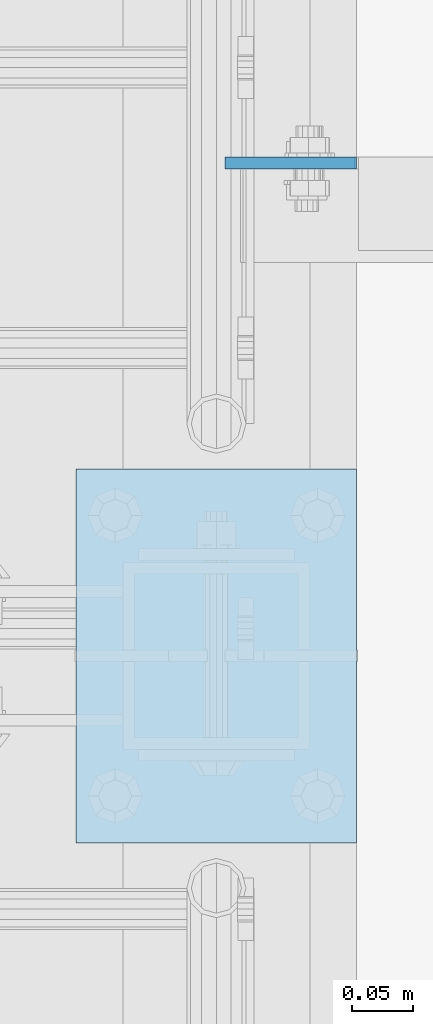
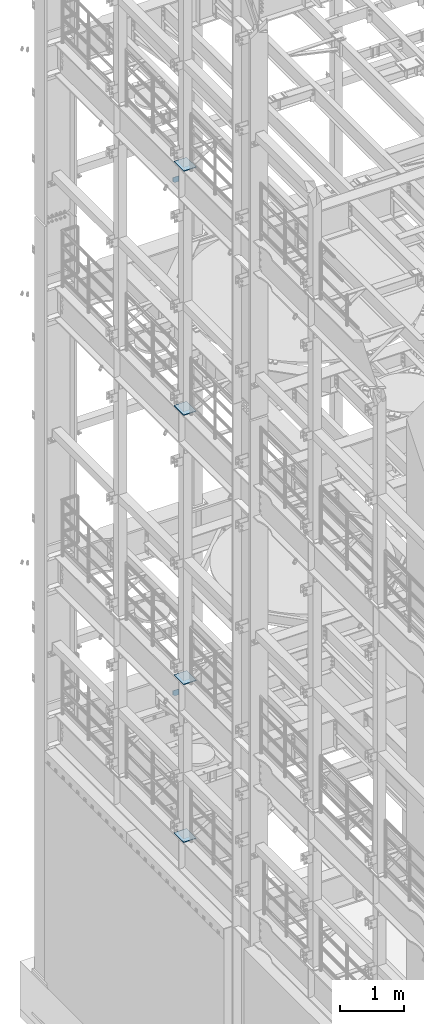
# One storey, part 1708 of 1876: 6 plates, 6 elements without a shape of their own.
"""IFC2X3 building model written with IfcOpenShell, lengths in millimetres."""

from ifc_helpers import new_model, si_unit, frame, origin_with_axes, place, context, subcontext, project, spatial, faceted_brep, material, type_object, element, aggregate, save


model = new_model("IFC2X3")

# Units and contexts
model_context = context("Model", 3, precision=1e-05, world=origin_with_axes())
body_context = subcontext(model_context, "Body", "Model", "MODEL_VIEW")
ifc_project = project(units=[si_unit("LENGTHUNIT", "METRE", prefix="MILLI"), si_unit("AREAUNIT", "SQUARE_METRE"), si_unit("VOLUMEUNIT", "CUBIC_METRE"), si_unit("MASSUNIT", "GRAM", prefix="KILO"), si_unit("TIMEUNIT", "SECOND"), si_unit("PLANEANGLEUNIT", "RADIAN"), si_unit("SOLIDANGLEUNIT", "STERADIAN"), si_unit("THERMODYNAMICTEMPERATUREUNIT", "DEGREE_CELSIUS"), si_unit("LUMINOUSINTENSITYUNIT", "LUMEN")], contexts=[model_context])

# Site, building, storey
site_placement = place(None, origin_with_axes())
site = spatial("IfcSite", under=ifc_project, at=site_placement, CompositionType="ELEMENT")
building_placement = place(site_placement, origin_with_axes())
building = spatial("IfcBuilding", under=site, at=building_placement, Name="Undefined", CompositionType="ELEMENT")
storey_placement = place(building_placement, origin_with_axes())
storey = spatial("IfcBuildingStorey", under=building, at=storey_placement, Name="Undefined", CompositionType="ELEMENT", Elevation=0.0)

# Assembly, plate
assembly_1_placement = place(storey_placement, origin_with_axes())
assembly_1 = element("IfcElementAssembly", 1, at=assembly_1_placement, inside=storey, Name="BEAM", AssemblyPlace="NOTDEFINED", PredefinedType="RIGID_FRAME")
ifc_material = material(Name="STEEL/A36")
plate_type_1 = type_object("IfcPlateType", PredefinedType="NOTDEFINED")
plate_1_placement = place(assembly_1_placement, frame((114.355426115311, 10053.6375, 17386.3), z_axis=(-1.0, 0.0, 0.0), x_axis=(0.0, 0.0, 1.0)))
plate_1 = element("IfcPlate", 2, at=plate_1_placement, type_object=plate_type_1, material=ifc_material, Name="PLATE", context=body_context, shape_type="Brep", body=[
    faceted_brep([(0.0, -4.76249999999982, 0.0), (0.0, -4.76250000000073, 75.4616775512695), (0.0, 4.76250000000073, 75.4616775512695), (0.0, 4.76249999999982, 0.0), (31.75, -4.76250000000073, 107.21167755127), (31.75, 4.76250000000073, 107.21167755127), (102.393173217773, -4.76250000000073, 107.21167755127), (102.393173217773, 4.76250000000073, 107.21167755127), (102.393173217773, -4.76250000000073, 0.0), (102.393173217773, 4.76250000000073, 0.0)], [[[0, 1, 2, 3]], [[1, 4, 5, 2]], [[4, 6, 7, 5]], [[6, 8, 9, 7]], [[8, 0, 3, 9]], [[5, 7, 9, 3, 2]], [[8, 6, 4, 1, 0]]]),
])
aggregate(assembly_1, [plate_1])

assembly_2_placement = place(storey_placement, origin_with_axes())
assembly_2 = element("IfcElementAssembly", 3, at=assembly_2_placement, inside=storey, Name="BEAM", AssemblyPlace="NOTDEFINED", PredefinedType="RIGID_FRAME")
plate_type_2 = type_object("IfcPlateType", PredefinedType="NOTDEFINED")
plate_2_placement = place(assembly_2_placement, frame((7.14374999999999, 10053.6375, 7556.5), z_axis=(0.0, 0.0, 1.0), x_axis=(1.0, 0.0, 0.0)))
plate_2 = element("IfcPlate", 4, at=plate_2_placement, type_object=plate_type_2, material=ifc_material, Name="PLATE", context=body_context, shape_type="Brep", body=[
    faceted_brep([(-9.76996261670138e-14, -4.76250000000073, 31.75), (-1.00364161426114e-13, -4.76250000000073, 106.301628112793), (-1.00364161426114e-13, 4.76250000000073, 106.301628112793), (-9.76996261670138e-14, 4.76250000000073, 31.75), (106.018096923828, -4.76250000000073, 106.301628112793), (106.018096923828, 4.76250000000073, 106.301628112793), (106.018096923828, -4.76250000000073, 0.0), (106.018096923828, 4.76250000000073, 0.0), (31.75, -4.76250000000073, 0.0), (31.75, 4.76250000000073, 0.0)], [[[0, 1, 2, 3]], [[1, 4, 5, 2]], [[4, 6, 7, 5]], [[6, 8, 9, 7]], [[8, 0, 3, 9]], [[5, 7, 9, 3, 2]], [[8, 6, 4, 1, 0]]]),
])
aggregate(assembly_2, [plate_2])

assembly_3_placement = place(storey_placement, origin_with_axes())
assembly_3 = element("IfcElementAssembly", 5, at=assembly_3_placement, inside=storey, Name="BEAM", AssemblyPlace="NOTDEFINED", PredefinedType="RIGID_FRAME")
plate_type_3 = type_object("IfcPlateType", PredefinedType="NOTDEFINED")
plate_3_placement = place(assembly_3_placement, frame((-114.3, 9499.6, 17989.55), z_axis=(0.0, 1.0, 0.0), x_axis=(1.0, 0.0, 0.0)))
plate_3 = element("IfcPlate", 6, at=plate_3_placement, type_object=plate_type_3, material=ifc_material, Name="PLATE", context=body_context, shape_type="Brep", body=[
    faceted_brep([(0.0, -6.35000000000036, 0.0), (0.0, -6.35000000000036, 304.799987792969), (0.0, 6.35000000000036, 304.799987792969), (0.0, 6.35000000000036, 0.0), (228.600006103516, -6.34999999999854, 304.799987792969), (228.600006103516, 6.34999999999854, 304.799987792969), (228.600006103516, -6.34999999999854, 0.0), (228.600006103516, 6.34999999999854, 0.0)], [[[0, 1, 2, 3]], [[1, 4, 5, 2]], [[4, 6, 7, 5]], [[6, 0, 3, 7]], [[5, 7, 3, 2]], [[6, 4, 1, 0]]]),
])
aggregate(assembly_3, [plate_3])

assembly_4_placement = place(storey_placement, origin_with_axes())
assembly_4 = element("IfcElementAssembly", 7, at=assembly_4_placement, inside=storey, Name="BEAM", AssemblyPlace="NOTDEFINED", PredefinedType="RIGID_FRAME")
plate_4_placement = place(assembly_4_placement, frame((-114.3, 9499.6, 13315.95), z_axis=(0.0, 1.0, 0.0), x_axis=(1.0, 0.0, 0.0)))
plate_4 = element("IfcPlate", 8, at=plate_4_placement, type_object=plate_type_3, material=ifc_material, Name="PLATE", context=body_context, shape_type="Brep", body=[
    faceted_brep([(0.0, -6.35000000000036, 0.0), (0.0, -6.35000000000036, 304.799987792969), (0.0, 6.35000000000036, 304.799987792969), (0.0, 6.35000000000036, 0.0), (228.600006103516, -6.34999999999854, 304.799987792969), (228.600006103516, 6.34999999999854, 304.799987792969), (228.600006103516, -6.34999999999854, 0.0), (228.600006103516, 6.34999999999854, 0.0)], [[[0, 1, 2, 3]], [[1, 4, 5, 2]], [[4, 6, 7, 5]], [[6, 0, 3, 7]], [[5, 7, 3, 2]], [[6, 4, 1, 0]]]),
])
aggregate(assembly_4, [plate_4])

assembly_5_placement = place(storey_placement, origin_with_axes())
assembly_5 = element("IfcElementAssembly", 9, at=assembly_5_placement, inside=storey, Name="BEAM", AssemblyPlace="NOTDEFINED", PredefinedType="RIGID_FRAME")
plate_5_placement = place(assembly_5_placement, frame((-114.3, 9499.6, 8159.75), z_axis=(0.0, 1.0, 0.0), x_axis=(1.0, 0.0, 0.0)))
plate_5 = element("IfcPlate", 10, at=plate_5_placement, type_object=plate_type_3, material=ifc_material, Name="PLATE", context=body_context, shape_type="Brep", body=[
    faceted_brep([(0.0, -6.35000000000036, 0.0), (0.0, -6.35000000000036, 304.799987792969), (0.0, 6.35000000000036, 304.799987792969), (0.0, 6.35000000000036, 0.0), (228.600006103516, -6.34999999999854, 304.799987792969), (228.600006103516, 6.34999999999854, 304.799987792969), (228.600006103516, -6.34999999999854, 0.0), (228.600006103516, 6.34999999999854, 0.0)], [[[0, 1, 2, 3]], [[1, 4, 5, 2]], [[4, 6, 7, 5]], [[6, 0, 3, 7]], [[5, 7, 3, 2]], [[6, 4, 1, 0]]]),
])
aggregate(assembly_5, [plate_5])

assembly_6_placement = place(storey_placement, origin_with_axes())
assembly_6 = element("IfcElementAssembly", 11, at=assembly_6_placement, inside=storey, Name="BEAM", AssemblyPlace="NOTDEFINED", PredefinedType="RIGID_FRAME")
plate_6_placement = place(assembly_6_placement, frame((-114.3, 9499.6, 5137.15), z_axis=(0.0, 1.0, 0.0), x_axis=(1.0, 0.0, 0.0)))
plate_6 = element("IfcPlate", 12, at=plate_6_placement, type_object=plate_type_3, material=ifc_material, Name="PLATE", context=body_context, shape_type="Brep", body=[
    faceted_brep([(0.0, -6.35000000000036, 0.0), (0.0, -6.35000000000036, 304.799987792969), (0.0, 6.35000000000036, 304.799987792969), (0.0, 6.35000000000036, 0.0), (228.600006103516, -6.34999999999854, 304.799987792969), (228.600006103516, 6.34999999999854, 304.799987792969), (228.600006103516, -6.34999999999854, 0.0), (228.600006103516, 6.34999999999854, 0.0)], [[[0, 1, 2, 3]], [[1, 4, 5, 2]], [[4, 6, 7, 5]], [[6, 0, 3, 7]], [[5, 7, 3, 2]], [[6, 4, 1, 0]]]),
])
aggregate(assembly_6, [plate_6])

save(model, "model.ifc")
